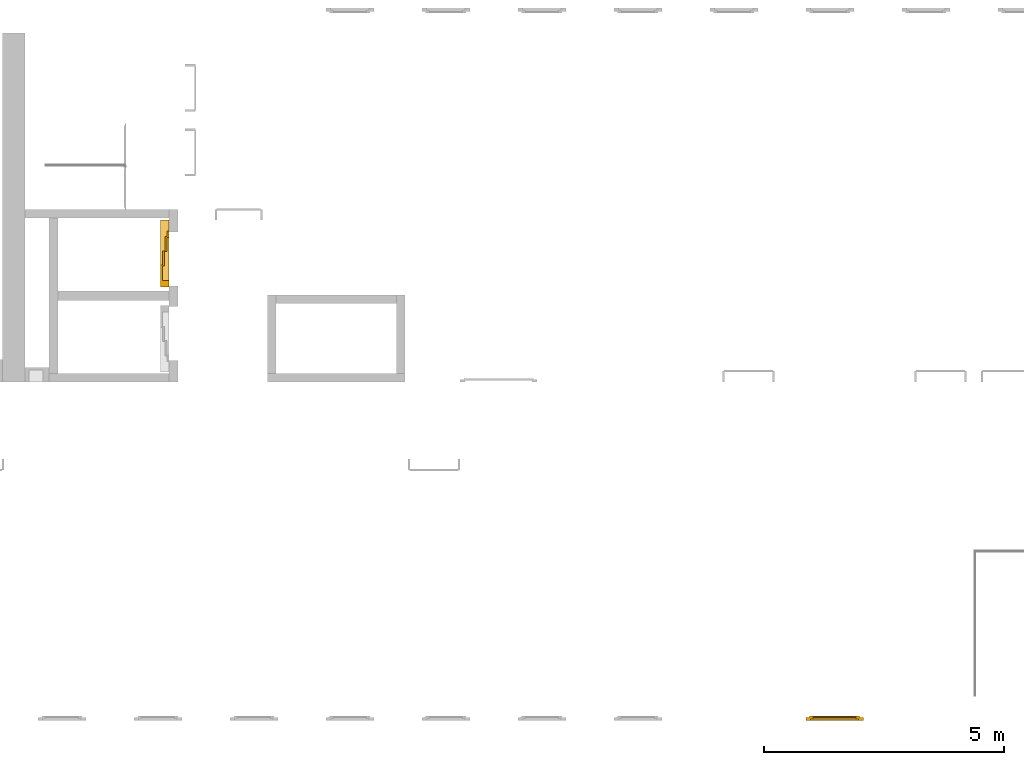
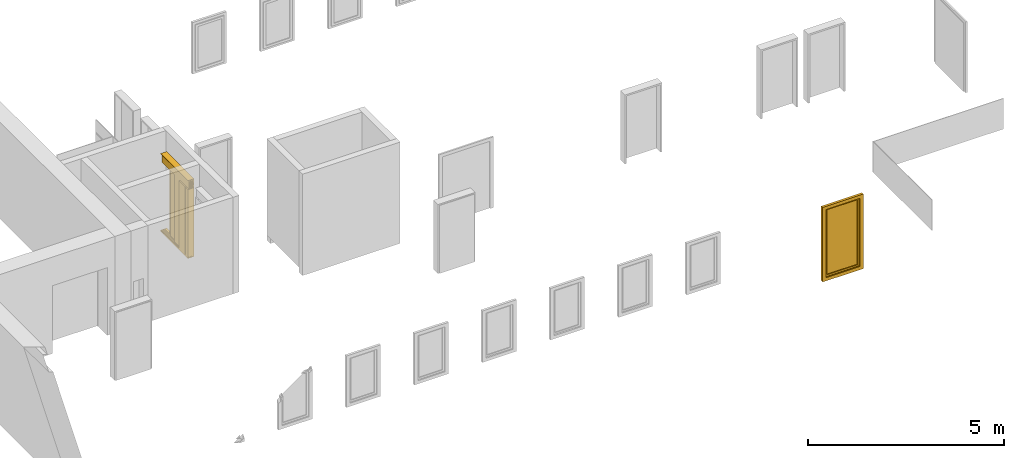
# One storey, part 5 of 5: 1 door, 1 window.
"""IFC4 building model written with IfcOpenShell, lengths in metres."""

from ifc_helpers import new_model, entity, si_unit, converted_unit, derived_unit, direction, frame, origin_with_axes, place, context, subcontext, project, spatial, polygons, source, transform, mapped, type_object, element, save


model = new_model("IFC4")

# Units and contexts
model_context = context("Model", 3, precision=1e-05, world=origin_with_axes(), true_north=direction((0.0, 1.0)))
body_context = subcontext(model_context, "Body", "Model", "MODEL_VIEW")
ifc_project = project(units=[si_unit("LENGTHUNIT", "METRE"), si_unit("AREAUNIT", "SQUARE_METRE"), si_unit("VOLUMEUNIT", "CUBIC_METRE"), converted_unit("PLANEANGLEUNIT", "DEGREE", entity("IfcPlaneAngleMeasure", 0.0174532925199433), si_unit("PLANEANGLEUNIT", "RADIAN"), dimensions=[0, 0, 0, 0, 0, 0, 0]), converted_unit("TIMEUNIT", "Year", entity("IfcTimeMeasure", 31557600.0), si_unit("TIMEUNIT", "SECOND"), dimensions=[0, 0, 1, 0, 0, 0, 0]), si_unit("MASSUNIT", "GRAM", prefix="KILO"), si_unit("THERMODYNAMICTEMPERATUREUNIT", "DEGREE_CELSIUS"), si_unit("LUMINOUSINTENSITYUNIT", "LUMEN"), si_unit("ENERGYUNIT", "JOULE", prefix="MEGA"), derived_unit("THERMALCONDUCTANCEUNIT", [(si_unit("POWERUNIT", "WATT"), 1), (si_unit("LENGTHUNIT", "METRE"), -1), (si_unit("THERMODYNAMICTEMPERATUREUNIT", "KELVIN"), -1)]), derived_unit("SPECIFICHEATCAPACITYUNIT", [(si_unit("ENERGYUNIT", "JOULE"), 1), (si_unit("MASSUNIT", "GRAM", prefix="KILO"), -1), (si_unit("THERMODYNAMICTEMPERATUREUNIT", "KELVIN"), -1)]), derived_unit("MASSDENSITYUNIT", [(si_unit("MASSUNIT", "GRAM", prefix="KILO"), 1), (si_unit("VOLUMEUNIT", "CUBIC_METRE"), -1)])], contexts=[model_context])

# Site, building, storey
site_placement = place(None, origin_with_axes())
site = spatial("IfcSite", under=ifc_project, at=site_placement, CompositionType="ELEMENT")
building_placement = place(None, origin_with_axes())
building = spatial("IfcBuilding", under=site, at=building_placement, CompositionType="ELEMENT")
storey_placement = place(None, frame((0.0, 0.0, 4.5), z_axis=(0.0, 0.0, 1.0), x_axis=(1.0, 0.0, 0.0)))
storey = spatial("IfcBuildingStorey", under=building, at=storey_placement, Name="1 OG", CompositionType="ELEMENT", Elevation=4.5)

# Window
window_type = type_object("IfcWindowType", Name="1-27", PartitioningType="SINGLE_PANEL", PredefinedType="WINDOW")
window_placement = place(None, frame((44.723, 0.0, 4.5), z_axis=(0.0, 0.0, 1.0), x_axis=(1.0, 0.0, 0.0)))
element("IfcWindow", 1, at=window_placement, inside=storey, type_object=window_type, Name="Fenster-001", OverallHeight=2.32, OverallWidth=1.2, context=body_context, shape_type="Tessellation", body=[
    polygons([(0.0, 0.0, 0.0), (0.0, 0.070000000000001, 0.0), (0.100000000000001, 0.070000000000001, 0.0999999999999996), (0.100000000000001, 0.0, 0.0999999999999996), (0.0, 0.0, 2.32), (0.0, 0.0700000000000009, 2.32), (0.100000000000001, 0.0700000000000009, 2.22), (0.100000000000001, 0.0, 2.22)], [[[1, 2, 3, 4]], [[5, 6, 2, 1]], [[2, 6, 7, 3]], [[4, 3, 7, 8]], [[1, 4, 8, 5]], [[8, 7, 6, 5]]], closed=True),
    polygons([(1.2, 0.0, 0.0), (1.2, 0.0700000000000007, 0.0), (1.2, 0.0700000000000006, 2.32), (1.2, 0.0, 2.32), (1.1, 0.0, 0.0999999999999996), (1.1, 0.0700000000000008, 0.0999999999999996), (1.1, 0.0700000000000006, 2.22), (1.1, 0.0, 2.22)], [[[1, 2, 3, 4]], [[5, 6, 2, 1]], [[2, 6, 7, 3]], [[4, 3, 7, 8]], [[1, 4, 8, 5]], [[8, 7, 6, 5]]], closed=True),
    polygons([(0.0, 0.0, 0.0), (0.0, 0.070000000000001, 0.0), (1.2, 0.0700000000000007, 0.0), (1.2, 0.0, 0.0), (0.100000000000001, 0.0, 0.0999999999999996), (0.100000000000001, 0.070000000000001, 0.0999999999999996), (0.600000000000001, 0.0700000000000009, 0.0999999999999996), (1.1, 0.0700000000000008, 0.0999999999999996), (1.1, 0.0, 0.0999999999999996), (0.600000000000001, 0.0, 0.0999999999999996)], [[[1, 2, 3, 4]], [[5, 6, 2, 1]], [[2, 6, 7, 8, 3]], [[4, 3, 8, 9]], [[1, 4, 9, 10, 5]], [[10, 7, 6, 5]], [[9, 8, 7, 10]]], closed=True),
    polygons([(0.0, 0.0, 2.32), (0.0, 0.0700000000000009, 2.32), (0.100000000000001, 0.0700000000000009, 2.22), (0.100000000000001, 0.0, 2.22), (1.2, 0.0, 2.32), (1.2, 0.0700000000000006, 2.32), (1.1, 0.0700000000000006, 2.22), (0.600000000000001, 0.0700000000000008, 2.22), (0.600000000000001, 0.0, 2.22), (1.1, 0.0, 2.22)], [[[1, 2, 3, 4]], [[5, 6, 2, 1]], [[2, 6, 7, 8, 3]], [[4, 3, 8, 9]], [[1, 4, 9, 10, 5]], [[10, 7, 6, 5]], [[9, 8, 7, 10]]], closed=True),
    polygons([(0.0799999999999983, 0.070000000000001, 0.0800000000000001), (0.0799999999999983, 0.100000000000001, 0.0800000000000001), (0.149999999999999, 0.100000000000001, 0.15), (0.149999999999999, 0.070000000000001, 0.15), (0.0799999999999983, 0.0700000000000009, 2.24), (0.0799999999999983, 0.100000000000001, 2.24), (0.149999999999999, 0.100000000000001, 2.17), (0.149999999999999, 0.0700000000000009, 2.17)], [[[1, 2, 3, 4]], [[5, 6, 2, 1]], [[2, 6, 7, 3]], [[4, 3, 7, 8]], [[1, 4, 8, 5]], [[8, 7, 6, 5]]], closed=True),
    polygons([(1.12, 0.0700000000000008, 0.0800000000000001), (1.05, 0.0700000000000008, 0.15), (1.05, 0.100000000000001, 0.15), (1.12, 0.100000000000001, 0.0800000000000001), (1.12, 0.0700000000000006, 2.24), (1.05, 0.0700000000000006, 2.17), (1.05, 0.100000000000001, 2.17), (1.12, 0.100000000000001, 2.24)], [[[1, 2, 3, 4]], [[1, 5, 6, 2]], [[2, 6, 7, 3]], [[4, 3, 7, 8]], [[5, 1, 4, 8]], [[6, 5, 8, 7]]], closed=True),
    polygons([(0.0799999999999983, 0.070000000000001, 0.0800000000000001), (0.0799999999999983, 0.100000000000001, 0.0800000000000001), (1.12, 0.100000000000001, 0.0800000000000001), (1.12, 0.0700000000000008, 0.0800000000000001), (0.149999999999999, 0.070000000000001, 0.15), (0.149999999999999, 0.100000000000001, 0.15), (1.05, 0.100000000000001, 0.15), (1.05, 0.0700000000000008, 0.15)], [[[1, 2, 3, 4]], [[5, 6, 2, 1]], [[2, 6, 7, 3]], [[4, 3, 7, 8]], [[1, 4, 8, 5]], [[8, 7, 6, 5]]], closed=True),
    polygons([(0.0799999999999983, 0.0700000000000009, 2.24), (1.12, 0.0700000000000006, 2.24), (1.12, 0.100000000000001, 2.24), (0.0799999999999983, 0.100000000000001, 2.24), (0.149999999999999, 0.0700000000000009, 2.17), (1.05, 0.0700000000000006, 2.17), (1.05, 0.100000000000001, 2.17), (0.149999999999999, 0.100000000000001, 2.17)], [[[1, 2, 3, 4]], [[1, 5, 6, 2]], [[2, 6, 7, 3]], [[4, 3, 7, 8]], [[5, 1, 4, 8]], [[6, 5, 8, 7]]], closed=True),
    polygons([(0.100000000000001, 0.040000000000001, 0.0999999999999996), (0.100000000000001, 0.070000000000001, 0.0999999999999996), (0.149999999999999, 0.070000000000001, 0.15), (0.149999999999999, 0.040000000000001, 0.15), (0.100000000000001, 0.0400000000000009, 2.22), (0.100000000000001, 0.0700000000000009, 2.22), (0.149999999999999, 0.0700000000000009, 2.17), (0.149999999999999, 0.0400000000000009, 2.17)], [[[1, 2, 3, 4]], [[5, 6, 2, 1]], [[2, 6, 7, 3]], [[4, 3, 7, 8]], [[1, 4, 8, 5]], [[8, 7, 6, 5]]], closed=True),
    polygons([(1.1, 0.0400000000000008, 0.0999999999999996), (1.05, 0.0400000000000008, 0.15), (1.05, 0.0700000000000008, 0.15), (1.1, 0.0700000000000008, 0.0999999999999996), (1.1, 0.0400000000000006, 2.22), (1.05, 0.0400000000000007, 2.17), (1.05, 0.0700000000000006, 2.17), (1.1, 0.0700000000000006, 2.22)], [[[1, 2, 3, 4]], [[1, 5, 6, 2]], [[2, 6, 7, 3]], [[4, 3, 7, 8]], [[5, 1, 4, 8]], [[6, 5, 8, 7]]], closed=True),
    polygons([(0.100000000000001, 0.040000000000001, 0.0999999999999996), (0.100000000000001, 0.070000000000001, 0.0999999999999996), (1.1, 0.0700000000000008, 0.0999999999999996), (1.1, 0.0400000000000008, 0.0999999999999996), (0.149999999999999, 0.040000000000001, 0.15), (0.149999999999999, 0.070000000000001, 0.15), (1.05, 0.0700000000000008, 0.15), (1.05, 0.0400000000000008, 0.15)], [[[1, 2, 3, 4]], [[5, 6, 2, 1]], [[2, 6, 7, 3]], [[4, 3, 7, 8]], [[1, 4, 8, 5]], [[8, 7, 6, 5]]], closed=True),
    polygons([(0.100000000000001, 0.0400000000000009, 2.22), (1.1, 0.0400000000000006, 2.22), (1.1, 0.0700000000000006, 2.22), (0.100000000000001, 0.0700000000000009, 2.22), (0.149999999999999, 0.0400000000000009, 2.17), (1.05, 0.0400000000000007, 2.17), (1.05, 0.0700000000000006, 2.17), (0.149999999999999, 0.0700000000000009, 2.17)], [[[1, 2, 3, 4]], [[1, 5, 6, 2]], [[2, 6, 7, 3]], [[4, 3, 7, 8]], [[5, 1, 4, 8]], [[6, 5, 8, 7]]], closed=True),
    polygons([(0.149999999999999, 0.065000000000001, 0.15), (0.149999999999999, 0.075000000000001, 0.15), (1.05, 0.0750000000000008, 0.15), (1.05, 0.0650000000000008, 0.15), (0.149999999999999, 0.0650000000000009, 2.17), (0.149999999999999, 0.0750000000000009, 2.17), (1.05, 0.0750000000000006, 2.17), (1.05, 0.0650000000000006, 2.17)], [[[1, 2, 3, 4]], [[5, 6, 2, 1]], [[2, 6, 7, 3]], [[4, 3, 7, 8]], [[1, 4, 8, 5]], [[8, 7, 6, 5]]], closed=True),
])

# Door
door_type = type_object("IfcDoorType", Name="27", OperationType="DOUBLE_DOOR_SLIDING", PredefinedType="DOOR")
shared_shape = source(origin_with_axes(), body_context, "Body", "Tessellation", [
    polygons([(0.808333333333334, 0.135, 2.1), (-0.585, 0.135, 2.1), (-0.585, 0.135, 2.138), (0.808333333333334, 0.135, 2.138), (0.808333333333334, 0.0, 2.1), (-0.585, 0.0, 2.1), (-0.585, 0.0, 2.38), (-0.585, 0.18, 2.38), (-0.585, 0.18, 2.377), (-0.585, 0.00299999999999992, 2.377), (-0.585, 0.00299999999999992, 2.103), (-0.585, 0.132, 2.103), (-0.585, 0.132, 2.138), (0.808333333333334, 0.132, 2.138), (0.808333333333334, 0.132, 2.103), (0.808333333333334, 0.003, 2.103), (0.808333333333334, 0.003, 2.377), (0.808333333333334, 0.18, 2.377), (0.808333333333334, 0.18, 2.38), (0.808333333333334, 0.0, 2.38)], [[[1, 2, 3, 4]], [[5, 6, 2, 1]], [[2, 6, 7, 8, 9, 10, 11, 12, 13, 3]], [[4, 3, 13, 14]], [[1, 4, 14, 15, 16, 17, 18, 19, 20, 5]], [[20, 7, 6, 5]], [[19, 8, 7, 20]], [[18, 9, 8, 19]], [[17, 10, 9, 18]], [[16, 11, 10, 17]], [[15, 12, 11, 16]], [[14, 13, 12, 15]]], closed=True),
    polygons([(0.808333333333334, 0.05, 2.103), (-0.585, 0.0499999999999999, 2.103), (-0.585, 0.0549999999999999, 2.103), (0.808333333333334, 0.055, 2.103), (0.808333333333334, 0.05, 2.34), (-0.585, 0.0499999999999999, 2.34), (-0.585, 0.0549999999999999, 2.34), (0.808333333333334, 0.055, 2.34)], [[[1, 2, 3, 4]], [[5, 6, 2, 1]], [[2, 6, 7, 3]], [[4, 3, 7, 8]], [[1, 4, 8, 5]], [[8, 7, 6, 5]]], closed=True),
    polygons([(0.808333333333334, 0.05, 2.33), (-0.585, 0.0499999999999999, 2.33), (-0.585, 0.0399999999999999, 2.33), (0.808333333333334, 0.04, 2.33), (0.808333333333334, 0.05, 2.27), (-0.585, 0.0499999999999999, 2.27), (-0.585, 0.0399999999999999, 2.27), (0.808333333333334, 0.04, 2.27)], [[[1, 2, 3, 4]], [[5, 6, 2, 1]], [[2, 6, 7, 3]], [[4, 3, 7, 8]], [[1, 4, 8, 5]], [[8, 7, 6, 5]]], closed=True),
    polygons([(0.808333333333334, 0.05, 2.2), (-0.585, 0.0499999999999999, 2.2), (-0.585, 0.0399999999999999, 2.2), (0.808333333333334, 0.04, 2.2), (0.808333333333334, 0.05, 2.16), (-0.585, 0.0499999999999999, 2.16), (-0.585, 0.0399999999999999, 2.16), (0.808333333333334, 0.04, 2.16)], [[[1, 2, 3, 4]], [[5, 6, 2, 1]], [[2, 6, 7, 3]], [[4, 3, 7, 8]], [[1, 4, 8, 5]], [[8, 7, 6, 5]]], closed=True),
    polygons([(0.808333333333334, 0.05, 2.27), (-0.585, 0.0499999999999999, 2.27), (-0.585, 0.0299999999999999, 2.27), (0.808333333333334, 0.03, 2.27), (0.808333333333334, 0.05, 2.2), (-0.585, 0.0499999999999999, 2.2), (-0.585, 0.0299999999999999, 2.2), (0.808333333333334, 0.03, 2.2)], [[[1, 2, 3, 4]], [[5, 6, 2, 1]], [[2, 6, 7, 3]], [[4, 3, 7, 8]], [[1, 4, 8, 5]], [[8, 7, 6, 5]]], closed=True),
    polygons([(0.808333333333334, 0.095, 2.103), (-0.585, 0.0949999999999999, 2.103), (-0.585, 0.0999999999999999, 2.103), (0.808333333333334, 0.1, 2.103), (0.808333333333334, 0.095, 2.34), (-0.585, 0.0949999999999999, 2.34), (-0.585, 0.0999999999999999, 2.34), (0.808333333333334, 0.1, 2.34)], [[[1, 2, 3, 4]], [[5, 6, 2, 1]], [[2, 6, 7, 3]], [[4, 3, 7, 8]], [[1, 4, 8, 5]], [[8, 7, 6, 5]]], closed=True),
    polygons([(0.808333333333334, 0.095, 2.33), (-0.585, 0.0949999999999999, 2.33), (-0.585, 0.0849999999999999, 2.33), (0.808333333333334, 0.085, 2.33), (0.808333333333334, 0.095, 2.27), (-0.585, 0.0949999999999999, 2.27), (-0.585, 0.0849999999999999, 2.27), (0.808333333333334, 0.085, 2.27)], [[[1, 2, 3, 4]], [[5, 6, 2, 1]], [[2, 6, 7, 3]], [[4, 3, 7, 8]], [[1, 4, 8, 5]], [[8, 7, 6, 5]]], closed=True),
    polygons([(0.808333333333334, 0.095, 2.2), (-0.585, 0.0949999999999999, 2.2), (-0.585, 0.0849999999999999, 2.2), (0.808333333333334, 0.085, 2.2), (0.808333333333334, 0.095, 2.16), (-0.585, 0.0949999999999999, 2.16), (-0.585, 0.0849999999999999, 2.16), (0.808333333333334, 0.085, 2.16)], [[[1, 2, 3, 4]], [[5, 6, 2, 1]], [[2, 6, 7, 3]], [[4, 3, 7, 8]], [[1, 4, 8, 5]], [[8, 7, 6, 5]]], closed=True),
    polygons([(0.808333333333334, 0.095, 2.27), (-0.585, 0.0949999999999999, 2.27), (-0.585, 0.0749999999999999, 2.27), (0.808333333333334, 0.075, 2.27), (0.808333333333334, 0.095, 2.2), (-0.585, 0.0949999999999999, 2.2), (-0.585, 0.0749999999999999, 2.2), (0.808333333333334, 0.075, 2.2)], [[[1, 2, 3, 4]], [[5, 6, 2, 1]], [[2, 6, 7, 3]], [[4, 3, 7, 8]], [[1, 4, 8, 5]], [[8, 7, 6, 5]]], closed=True),
    polygons([(0.808333333333334, 0.14, 2.103), (-0.585, 0.14, 2.103), (-0.585, 0.145, 2.103), (0.808333333333334, 0.145, 2.103), (0.808333333333334, 0.14, 2.34), (-0.585, 0.14, 2.34), (-0.585, 0.145, 2.34), (0.808333333333334, 0.145, 2.34)], [[[1, 2, 3, 4]], [[5, 6, 2, 1]], [[2, 6, 7, 3]], [[4, 3, 7, 8]], [[1, 4, 8, 5]], [[8, 7, 6, 5]]], closed=True),
    polygons([(0.808333333333334, 0.14, 2.33), (-0.585, 0.14, 2.33), (-0.585, 0.13, 2.33), (0.808333333333334, 0.13, 2.33), (0.808333333333334, 0.14, 2.27), (-0.585, 0.14, 2.27), (-0.585, 0.13, 2.27), (0.808333333333334, 0.13, 2.27)], [[[1, 2, 3, 4]], [[5, 6, 2, 1]], [[2, 6, 7, 3]], [[4, 3, 7, 8]], [[1, 4, 8, 5]], [[8, 7, 6, 5]]], closed=True),
    polygons([(0.808333333333334, 0.14, 2.2), (-0.585, 0.14, 2.2), (-0.585, 0.13, 2.2), (0.808333333333334, 0.13, 2.2), (0.808333333333334, 0.14, 2.16), (-0.585, 0.14, 2.16), (-0.585, 0.13, 2.16), (0.808333333333334, 0.13, 2.16)], [[[1, 2, 3, 4]], [[5, 6, 2, 1]], [[2, 6, 7, 3]], [[4, 3, 7, 8]], [[1, 4, 8, 5]], [[8, 7, 6, 5]]], closed=True),
    polygons([(0.808333333333334, 0.14, 2.27), (-0.585, 0.14, 2.27), (-0.585, 0.12, 2.27), (0.808333333333334, 0.12, 2.27), (0.808333333333334, 0.14, 2.2), (-0.585, 0.14, 2.2), (-0.585, 0.12, 2.2), (0.808333333333334, 0.12, 2.2)], [[[1, 2, 3, 4]], [[5, 6, 2, 1]], [[2, 6, 7, 3]], [[4, 3, 7, 8]], [[1, 4, 8, 5]], [[8, 7, 6, 5]]], closed=True),
    polygons([(0.808333333333334, 0.0, 0.0), (-0.585, 0.0, 0.0), (-0.585, 0.0, -0.04), (0.808333333333334, 0.0, -0.04), (0.808333333333334, 0.065, 0.0), (-0.585, 0.0649999999999999, 0.0), (-0.585, 0.0649999999999999, -0.01), (-0.585, 0.0749999999999999, -0.01), (-0.585, 0.0749999999999999, 0.0), (-0.585, 0.11, 0.0), (-0.585, 0.11, -0.01), (-0.585, 0.12, -0.01), (-0.585, 0.12, 0.0), (-0.585, 0.155, 0.0), (-0.585, 0.155, -0.01), (-0.585, 0.165, -0.01), (-0.585, 0.165, 0.0), (-0.585, 0.18, 0.0), (-0.585, 0.18, -0.04), (0.808333333333334, 0.18, -0.04), (0.808333333333334, 0.18, 0.0), (0.808333333333334, 0.165, 0.0), (0.808333333333334, 0.165, -0.01), (0.808333333333334, 0.155, -0.01), (0.808333333333334, 0.155, 0.0), (0.808333333333334, 0.12, 0.0), (0.808333333333334, 0.12, -0.01), (0.808333333333334, 0.11, -0.01), (0.808333333333334, 0.11, 0.0), (0.808333333333334, 0.075, 0.0), (0.808333333333334, 0.075, -0.01), (0.808333333333334, 0.065, -0.01)], [[[1, 2, 3, 4]], [[5, 6, 2, 1]], [[2, 6, 7, 8, 9, 10, 11, 12, 13, 14, 15, 16, 17, 18, 19, 3]], [[4, 3, 19, 20]], [[1, 4, 20, 21, 22, 23, 24, 25, 26, 27, 28, 29, 30, 31, 32, 5]], [[32, 7, 6, 5]], [[31, 8, 7, 32]], [[30, 9, 8, 31]], [[29, 10, 9, 30]], [[28, 11, 10, 29]], [[27, 12, 11, 28]], [[26, 13, 12, 27]], [[25, 14, 13, 26]], [[24, 15, 14, 25]], [[23, 16, 15, 24]], [[22, 17, 16, 23]], [[21, 18, 17, 22]], [[20, 19, 18, 21]]], closed=True),
    polygons([(0.45, 0.0, 0.0), (0.45, 0.0, 2.1), (0.45, 0.0449999999999999, 2.1), (0.45, 0.045, 0.0), (0.585, 0.0, 0.0), (0.585, 0.0, 2.1), (0.585, 0.0449999999999999, 2.1), (0.585, 0.045, 0.0)], [[[1, 2, 3, 4]], [[5, 6, 2, 1]], [[2, 6, 7, 3]], [[4, 3, 7, 8]], [[1, 4, 8, 5]], [[8, 7, 6, 5]]], closed=True),
    polygons([(-0.585, 0.0, 0.0), (-0.585, 0.0, 2.1), (-0.585, 0.18, 2.1), (-0.585, 0.18, 0.0), (-0.45, 0.0, 0.0), (-0.45, 0.0, 2.1), (-0.45, 0.18, 2.1), (-0.45, 0.18, 0.0)], [[[1, 2, 3, 4]], [[5, 6, 2, 1]], [[2, 6, 7, 3]], [[4, 3, 7, 8]], [[1, 4, 8, 5]], [[8, 7, 6, 5]]], closed=True),
    polygons([(0.665, -0.18, 0.8), (0.745, -0.18, 0.8), (0.745, -0.183, 0.8), (0.665, -0.183, 0.8), (0.665, -0.18, 1.06), (0.745, -0.18, 1.06), (0.675, -0.18, 1.03), (0.675, -0.18, 0.94), (0.735, -0.18, 0.94), (0.735, -0.18, 1.03), (0.695, -0.18, 0.84), (0.715, -0.18, 0.84), (0.715, -0.18, 0.86), (0.695, -0.18, 0.86), (0.695, -0.18, 0.88), (0.715, -0.18, 0.88), (0.715, -0.18, 0.9), (0.695, -0.18, 0.9), (0.745, -0.183, 1.06), (0.665, -0.183, 1.06), (0.675, -0.183, 1.03), (0.735, -0.183, 1.03), (0.735, -0.183, 0.94), (0.675, -0.183, 0.94), (0.695, -0.183, 0.84), (0.695, -0.183, 0.86), (0.715, -0.183, 0.86), (0.715, -0.183, 0.84), (0.695, -0.183, 0.88), (0.695, -0.183, 0.9), (0.715, -0.183, 0.9), (0.715, -0.183, 0.88)], [[[1, 2, 3, 4]], [[1, 5, 6, 2], [7, 8, 9, 10], [11, 12, 13, 14], [15, 16, 17, 18]], [[2, 6, 19, 3]], [[4, 3, 19, 20], [21, 22, 23, 24], [25, 26, 27, 28], [29, 30, 31, 32]], [[5, 1, 4, 20]], [[6, 5, 20, 19]], [[8, 7, 21, 24]], [[9, 8, 24, 23]], [[10, 9, 23, 22]], [[7, 10, 22, 21]], [[12, 11, 25, 28]], [[13, 12, 28, 27]], [[14, 13, 27, 26]], [[11, 14, 26, 25]], [[16, 15, 29, 32]], [[17, 16, 32, 31]], [[18, 17, 31, 30]], [[15, 18, 30, 29]]], closed=True),
    polygons([(0.675, -0.18, 0.94), (0.735, -0.18, 0.94), (0.735, -0.1825, 0.94), (0.675, -0.1825, 0.94), (0.675, -0.18, 1.03), (0.735, -0.18, 1.03), (0.735, -0.1825, 1.03), (0.675, -0.1825, 1.03)], [[[1, 2, 3, 4]], [[1, 5, 6, 2]], [[2, 6, 7, 3]], [[4, 3, 7, 8]], [[5, 1, 4, 8]], [[6, 5, 8, 7]]], closed=True),
    polygons([(0.689, -0.183, 1.005), (0.695, -0.183, 1.021), (0.701, -0.183, 1.005)], [[[1, 2, 3]]], closed=False),
    polygons([(0.715, -0.183, 1.005), (0.709, -0.183, 1.021), (0.721, -0.183, 1.021)], [[[1, 2, 3]]], closed=False),
    polygons([(0.702272727272727, -0.1835, 0.982), (0.702272727272727, -0.1835, 0.971636363636364), (0.700909090909091, -0.1835, 0.970272727272727), (0.699545454545455, -0.1835, 0.971636363636364), (0.699545454545455, -0.1835, 0.982), (0.700909090909091, -0.1835, 0.983363636363636)], [[[1, 2, 3, 4, 5, 6]]], closed=False),
    polygons([(0.702272727272727, -0.1835, 0.968363636363636), (0.702272727272727, -0.1835, 0.958), (0.700909090909091, -0.1835, 0.956636363636364), (0.699545454545455, -0.1835, 0.958), (0.699545454545455, -0.1835, 0.968363636363636), (0.700909090909091, -0.1835, 0.969727272727273)], [[[1, 2, 3, 4, 5, 6]]], closed=False),
    polygons([(0.721090909090909, -0.1835, 0.982272727272727), (0.710727272727273, -0.1835, 0.982272727272727), (0.709363636363637, -0.1835, 0.983636363636364), (0.710727272727273, -0.1835, 0.985), (0.721090909090909, -0.1835, 0.985), (0.722454545454546, -0.1835, 0.983636363636364)], [[[1, 2, 3, 4, 5, 6]]], closed=False),
    polygons([(0.724090909090909, -0.1835, 0.982), (0.724090909090909, -0.1835, 0.971636363636364), (0.722727272727273, -0.1835, 0.970272727272727), (0.721363636363637, -0.1835, 0.971636363636364), (0.721363636363637, -0.1835, 0.982), (0.722727272727273, -0.1835, 0.983363636363636)], [[[1, 2, 3, 4, 5, 6]]], closed=False),
    polygons([(0.721090909090909, -0.1835, 0.968636363636364), (0.710727272727273, -0.1835, 0.968636363636364), (0.709363636363637, -0.1835, 0.97), (0.710727272727273, -0.1835, 0.971363636363636), (0.721090909090909, -0.1835, 0.971363636363636), (0.722454545454546, -0.1835, 0.97)], [[[1, 2, 3, 4, 5, 6]]], closed=False),
    polygons([(0.710454545454546, -0.1835, 0.968363636363636), (0.710454545454546, -0.1835, 0.958), (0.709090909090909, -0.1835, 0.956636363636364), (0.707727272727273, -0.1835, 0.958), (0.707727272727273, -0.1835, 0.968363636363636), (0.709090909090909, -0.1835, 0.969727272727273)], [[[1, 2, 3, 4, 5, 6]]], closed=False),
    polygons([(0.721090909090909, -0.1835, 0.955), (0.710727272727273, -0.1835, 0.955), (0.709363636363637, -0.1835, 0.956363636363636), (0.710727272727273, -0.1835, 0.957727272727273), (0.721090909090909, -0.1835, 0.957727272727273), (0.722454545454546, -0.1835, 0.956363636363636)], [[[1, 2, 3, 4, 5, 6]]], closed=False),
    polygons([(0.715, -0.18, 0.84), (0.695, -0.18, 0.84), (0.695, -0.18, 0.86), (0.715, -0.18, 0.86), (0.715000000094772, -0.1815, 0.839999999610484), (0.694999999610484, -0.1815, 0.839999999610484), (0.694999999610484, -0.1815, 0.860000000094772), (0.715000000094772, -0.1815, 0.860000000094772), (0.713599999679029, -0.182900000415742, 0.841400000026226), (0.696400000026226, -0.182900000415742, 0.841400000026226), (0.696400000026226, -0.182900000415742, 0.858599999679029), (0.713599999679029, -0.182900000415742, 0.858599999679029)], [[[1, 2, 3, 4]], [[2, 1, 5, 6]], [[3, 2, 6, 7]], [[4, 3, 7, 8]], [[1, 4, 8, 5]], [[6, 5, 9, 10]], [[7, 6, 10, 11]], [[8, 7, 11, 12]], [[5, 8, 12, 9]], [[11, 10, 9, 12]]], closed=True),
    polygons([(0.71, -0.183, 0.855), (0.705, -0.183, 0.844), (0.7, -0.183, 0.855)], [[[1, 2, 3]]], closed=False),
    polygons([(0.715, -0.18, 0.88), (0.695, -0.18, 0.88), (0.695, -0.18, 0.9), (0.715, -0.18, 0.9), (0.715000000094772, -0.1815, 0.879999999610484), (0.694999999610484, -0.1815, 0.879999999610484), (0.694999999610484, -0.1815, 0.900000000094772), (0.715000000094772, -0.1815, 0.900000000094772), (0.713599999679029, -0.182900000415742, 0.881400000026226), (0.696400000026226, -0.182900000415742, 0.881400000026226), (0.696400000026226, -0.182900000415742, 0.898599999679029), (0.713599999679029, -0.182900000415742, 0.898599999679029)], [[[1, 2, 3, 4]], [[2, 1, 5, 6]], [[3, 2, 6, 7]], [[4, 3, 7, 8]], [[1, 4, 8, 5]], [[6, 5, 9, 10]], [[7, 6, 10, 11]], [[8, 7, 11, 12]], [[5, 8, 12, 9]], [[11, 10, 9, 12]]], closed=True),
    polygons([(0.71, -0.183, 0.885), (0.7, -0.183, 0.885), (0.705, -0.183, 0.896)], [[[1, 2, 3]]], closed=False),
    polygons([(-0.126666666666667, 0.14, 0.003), (-0.445, 0.14, 0.003), (-0.445, 0.18, 0.003), (-0.126666666666667, 0.18, 0.003), (-0.126666666666667, 0.14, 2.1), (-0.445, 0.14, 2.1), (-0.445, 0.18, 2.1), (-0.126666666666667, 0.18, 2.1)], [[[1, 2, 3, 4]], [[1, 5, 6, 2]], [[2, 6, 7, 3]], [[4, 3, 7, 8]], [[5, 1, 4, 8]], [[6, 5, 8, 7]]], closed=True),
    polygons([(0.171666666666667, 0.095, 0.003), (-0.146666666666667, 0.095, 0.003), (-0.146666666666667, 0.135, 0.003), (0.171666666666667, 0.135, 0.003), (0.171666666666667, 0.095, 2.1), (-0.146666666666667, 0.095, 2.1), (-0.146666666666667, 0.135, 2.1), (0.171666666666667, 0.135, 2.1)], [[[1, 2, 3, 4]], [[1, 5, 6, 2]], [[2, 6, 7, 3]], [[4, 3, 7, 8]], [[5, 1, 4, 8]], [[6, 5, 8, 7]]], closed=True),
    polygons([(0.47, 0.05, 0.003), (0.151666666666667, 0.05, 0.003), (0.151666666666667, 0.09, 0.003), (0.47, 0.09, 0.003), (0.47, 0.05, 2.1), (0.151666666666667, 0.05, 2.1), (0.151666666666667, 0.09, 2.1), (0.47, 0.09, 2.1)], [[[1, 2, 3, 4]], [[1, 5, 6, 2]], [[2, 6, 7, 3]], [[4, 3, 7, 8]], [[5, 1, 4, 8]], [[6, 5, 8, 7]]], closed=True),
])
door_placement = place(None, frame((31.638, 9.16999994546756, 4.5), z_axis=(0.0, 0.0, 1.0), x_axis=(0.0, 1.0, 0.0)))
element("IfcDoor", 2, at=door_placement, inside=storey, type_object=door_type, OverallHeight=2.25, OverallWidth=1.13, context=body_context, shape_type="MappedRepresentation", body=[
    mapped(shared_shape, transform((0.450000000000001, 0.179999999999996, 0.0))),
])

save(model, "model.ifc")
